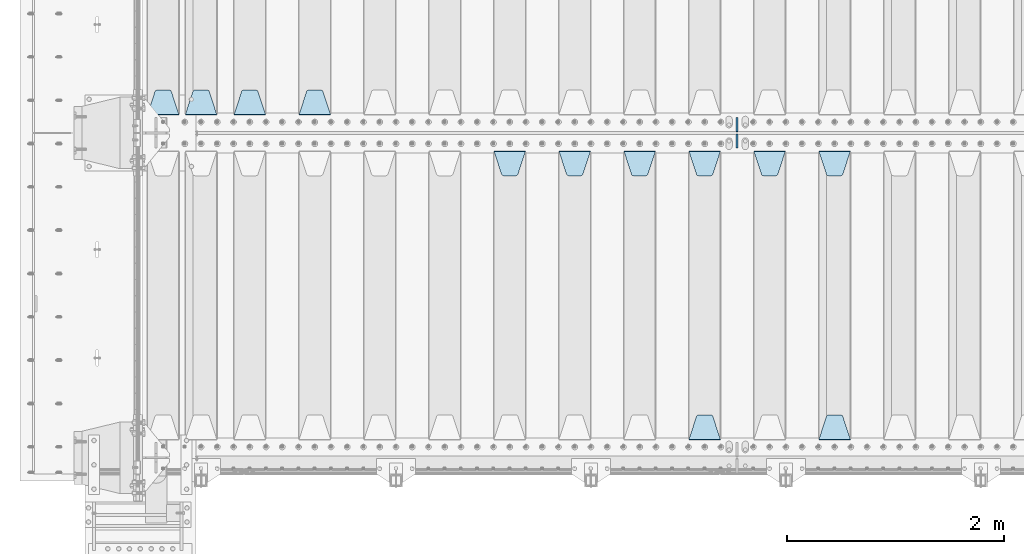
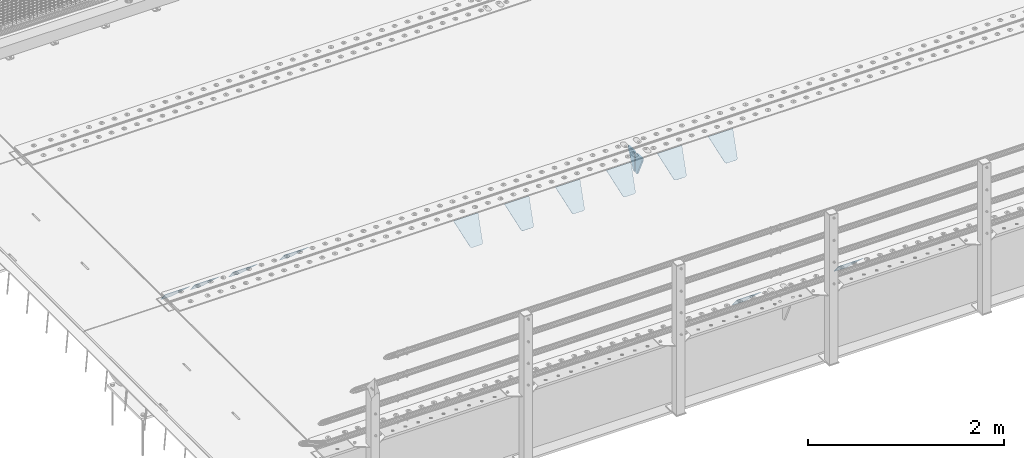
# One storey, part 199 of 247: 14 plates.
"""IFC2X3 building model written with IfcOpenShell, lengths in millimetres."""

from ifc_helpers import new_model, si_unit, frame, origin_with_axes, place, context, subcontext, project, spatial, faceted_brep, material, type_object, element, save


model = new_model("IFC2X3")

# Units and contexts
model_context = context("Model", 3, precision=1e-05, world=origin_with_axes())
body_context = subcontext(model_context, "Body", "Model", "MODEL_VIEW")
ifc_project = project(units=[si_unit("LENGTHUNIT", "METRE", prefix="MILLI"), si_unit("AREAUNIT", "SQUARE_METRE"), si_unit("VOLUMEUNIT", "CUBIC_METRE"), si_unit("MASSUNIT", "GRAM", prefix="KILO"), si_unit("TIMEUNIT", "SECOND"), si_unit("PLANEANGLEUNIT", "RADIAN"), si_unit("SOLIDANGLEUNIT", "STERADIAN"), si_unit("THERMODYNAMICTEMPERATUREUNIT", "DEGREE_CELSIUS"), si_unit("LUMINOUSINTENSITYUNIT", "LUMEN")], contexts=[model_context])

# Site, building, storey
site_placement = place(None, origin_with_axes())
site = spatial("IfcSite", under=ifc_project, at=site_placement, CompositionType="ELEMENT")
building_placement = place(site_placement, origin_with_axes())
building = spatial("IfcBuilding", under=site, at=building_placement, Name="Standard", CompositionType="ELEMENT")
storey_placement = place(building_placement, origin_with_axes())
storey = spatial("IfcBuildingStorey", under=building, at=storey_placement, Name="Undefined", CompositionType="ELEMENT", Elevation=0.0)

# Plates
ifc_material = material(Name="STEEL/S355N")
plate_type_1 = type_object("IfcPlateType", PredefinedType="NOTDEFINED")
plate_1_placement = place(storey_placement, frame((6255.0, 2831.76776695594, -1.767766952965), z_axis=(0.0, -0.707106781186548, -0.707106781186547), x_axis=(1.0, 0.0, 0.0)))
element("IfcPlate", 1, at=plate_1_placement, inside=storey, type_object=plate_type_1, material=ifc_material, context=body_context, shape_type="Brep", body=[
    faceted_brep([(0.0, -2.49999999999909, 0.0), (69.345504679477, -2.5, 300.17173142483), (69.345504679477, 2.50000000000091, 300.171731424831), (0.0, 2.5, -9.09494701772928e-13), (70.9274061199576, -2.5, 304.897442415399), (70.9274061199576, 2.50000000000091, 304.8974424154), (73.3818627772307, -2.49999999999909, 309.234538108527), (73.3818627772307, 2.5, 309.234538108526), (76.6187032999551, -2.5, 313.023683126102), (76.6187032999551, 2.50000000000091, 313.023683126102), (80.5190132704993, -2.49999999999909, 316.125672595371), (80.5190132704993, 2.50000000000091, 316.125672595372), (84.9395038596849, -2.49999999999909, 318.426546230476), (84.9395038596849, 2.5, 318.426546230475), (89.7177759439219, -2.5, 319.841774983274), (89.7177759439219, 2.50000000000091, 319.841774983275), (94.678286292652, -2.5, 320.319366455077), (94.678286292652, 2.50000000000091, 320.319366455077), (195.321713707348, -2.5, 320.319366455077), (195.321713707348, 2.50000000000091, 320.319366455077), (200.282224056078, -2.5, 319.841774983274), (200.282224056078, 2.50000000000091, 319.841774983275), (205.060496140315, -2.5, 318.426546230475), (205.060496140315, 2.5, 318.426546230474), (209.480986729501, -2.49999999999818, 316.12567259537), (209.480986729501, 2.50000000000091, 316.12567259537), (213.381296700045, -2.5, 313.023683126101), (213.381296700045, 2.50000000000091, 313.023683126101), (216.618137222769, -2.5, 309.234538108525), (216.618137222769, 2.5, 309.234538108525), (219.072593880042, -2.49999999999909, 304.897442415398), (219.072593880042, 2.5, 304.897442415398), (220.654495320523, -2.5, 300.17173142483), (220.654495320523, 2.50000000000091, 300.171731424831), (290.0, -2.49999999999909, 0.0), (290.0, 2.5, -9.09494701772928e-13)], [[[0, 1, 2, 3]], [[1, 4, 5, 2]], [[4, 6, 7, 5]], [[6, 8, 9, 7]], [[8, 10, 11, 9]], [[10, 12, 13, 11]], [[12, 14, 15, 13]], [[14, 16, 17, 15]], [[16, 18, 19, 17]], [[18, 20, 21, 19]], [[20, 22, 23, 21]], [[22, 24, 25, 23]], [[24, 26, 27, 25]], [[26, 28, 29, 27]], [[28, 30, 31, 29]], [[30, 32, 33, 31]], [[32, 34, 35, 33]], [[34, 0, 3, 35]], [[5, 7, 9, 11, 13, 15, 17, 19, 21, 23, 25, 27, 29, 31, 33, 35, 3, 2]], [[34, 32, 30, 28, 26, 24, 22, 20, 18, 16, 14, 12, 10, 8, 6, 4, 1, 0]]]),
])
plate_2_placement = place(storey_placement, frame((6545.0, 168.232233047034, -1.76776695296758), z_axis=(0.0, 0.707106781186548, -0.707106781186547), x_axis=(-1.0, 0.0, 0.0)))
element("IfcPlate", 2, at=plate_2_placement, inside=storey, type_object=plate_type_1, material=ifc_material, context=body_context, shape_type="Brep", body=[
    faceted_brep([(0.0, -2.49999999999909, 0.0), (69.345504679477, -2.5, 300.17173142483), (69.345504679477, 2.50000000000091, 300.171731424831), (0.0, 2.5, -9.09494701772928e-13), (70.9274061199576, -2.5, 304.897442415399), (70.9274061199576, 2.50000000000091, 304.8974424154), (73.3818627772307, -2.49999999999909, 309.234538108527), (73.3818627772307, 2.5, 309.234538108526), (76.6187032999551, -2.5, 313.023683126102), (76.6187032999551, 2.50000000000091, 313.023683126102), (80.5190132704993, -2.49999999999909, 316.125672595371), (80.5190132704993, 2.50000000000091, 316.125672595372), (84.9395038596849, -2.49999999999909, 318.426546230476), (84.9395038596849, 2.5, 318.426546230475), (89.7177759439219, -2.5, 319.841774983274), (89.7177759439219, 2.50000000000091, 319.841774983275), (94.678286292652, -2.5, 320.319366455077), (94.678286292652, 2.50000000000091, 320.319366455077), (195.321713707348, -2.5, 320.319366455077), (195.321713707348, 2.50000000000091, 320.319366455077), (200.282224056078, -2.5, 319.841774983274), (200.282224056078, 2.50000000000091, 319.841774983275), (205.060496140315, -2.5, 318.426546230475), (205.060496140315, 2.5, 318.426546230474), (209.480986729501, -2.49999999999818, 316.12567259537), (209.480986729501, 2.50000000000091, 316.12567259537), (213.381296700045, -2.5, 313.023683126101), (213.381296700045, 2.50000000000091, 313.023683126101), (216.618137222769, -2.5, 309.234538108525), (216.618137222769, 2.5, 309.234538108525), (219.072593880042, -2.49999999999909, 304.897442415398), (219.072593880042, 2.5, 304.897442415398), (220.654495320523, -2.5, 300.17173142483), (220.654495320523, 2.50000000000091, 300.171731424831), (290.0, -2.49999999999909, 0.0), (290.0, 2.5, -9.09494701772928e-13)], [[[0, 1, 2, 3]], [[1, 4, 5, 2]], [[4, 6, 7, 5]], [[6, 8, 9, 7]], [[8, 10, 11, 9]], [[10, 12, 13, 11]], [[12, 14, 15, 13]], [[14, 16, 17, 15]], [[16, 18, 19, 17]], [[18, 20, 21, 19]], [[20, 22, 23, 21]], [[22, 24, 25, 23]], [[24, 26, 27, 25]], [[26, 28, 29, 27]], [[28, 30, 31, 29]], [[30, 32, 33, 31]], [[32, 34, 35, 33]], [[34, 0, 3, 35]], [[5, 7, 9, 11, 13, 15, 17, 19, 21, 23, 25, 27, 29, 31, 33, 35, 3, 2]], [[34, 32, 30, 28, 26, 24, 22, 20, 18, 16, 14, 12, 10, 8, 6, 4, 1, 0]]]),
])
plate_3_placement = place(storey_placement, frame((5655.0, 2831.76776695594, -1.767766952965), z_axis=(0.0, -0.707106781186548, -0.707106781186547), x_axis=(1.0, 0.0, 0.0)))
element("IfcPlate", 3, at=plate_3_placement, inside=storey, type_object=plate_type_1, material=ifc_material, context=body_context, shape_type="Brep", body=[
    faceted_brep([(0.0, -2.49999999999909, 0.0), (69.345504679477, -2.5, 300.17173142483), (69.345504679477, 2.50000000000091, 300.171731424831), (0.0, 2.5, -9.09494701772928e-13), (70.9274061199576, -2.5, 304.897442415399), (70.9274061199576, 2.50000000000091, 304.8974424154), (73.3818627772307, -2.49999999999909, 309.234538108527), (73.3818627772307, 2.5, 309.234538108526), (76.6187032999551, -2.5, 313.023683126102), (76.6187032999551, 2.50000000000091, 313.023683126102), (80.5190132704993, -2.49999999999909, 316.125672595371), (80.5190132704993, 2.50000000000091, 316.125672595372), (84.9395038596849, -2.49999999999909, 318.426546230476), (84.9395038596849, 2.5, 318.426546230475), (89.7177759439219, -2.5, 319.841774983274), (89.7177759439219, 2.50000000000091, 319.841774983275), (94.678286292652, -2.5, 320.319366455077), (94.678286292652, 2.50000000000091, 320.319366455077), (195.321713707348, -2.5, 320.319366455077), (195.321713707348, 2.50000000000091, 320.319366455077), (200.282224056078, -2.5, 319.841774983274), (200.282224056078, 2.50000000000091, 319.841774983275), (205.060496140315, -2.5, 318.426546230475), (205.060496140315, 2.5, 318.426546230474), (209.480986729501, -2.49999999999818, 316.12567259537), (209.480986729501, 2.50000000000091, 316.12567259537), (213.381296700045, -2.5, 313.023683126101), (213.381296700045, 2.50000000000091, 313.023683126101), (216.618137222769, -2.5, 309.234538108525), (216.618137222769, 2.5, 309.234538108525), (219.072593880042, -2.49999999999909, 304.897442415398), (219.072593880042, 2.5, 304.897442415398), (220.654495320523, -2.5, 300.17173142483), (220.654495320523, 2.50000000000091, 300.171731424831), (290.0, -2.49999999999909, 0.0), (290.0, 2.5, -9.09494701772928e-13)], [[[0, 1, 2, 3]], [[1, 4, 5, 2]], [[4, 6, 7, 5]], [[6, 8, 9, 7]], [[8, 10, 11, 9]], [[10, 12, 13, 11]], [[12, 14, 15, 13]], [[14, 16, 17, 15]], [[16, 18, 19, 17]], [[18, 20, 21, 19]], [[20, 22, 23, 21]], [[22, 24, 25, 23]], [[24, 26, 27, 25]], [[26, 28, 29, 27]], [[28, 30, 31, 29]], [[30, 32, 33, 31]], [[32, 34, 35, 33]], [[34, 0, 3, 35]], [[5, 7, 9, 11, 13, 15, 17, 19, 21, 23, 25, 27, 29, 31, 33, 35, 3, 2]], [[34, 32, 30, 28, 26, 24, 22, 20, 18, 16, 14, 12, 10, 8, 6, 4, 1, 0]]]),
])
plate_4_placement = place(storey_placement, frame((5055.0, 2831.76776695594, -1.767766952965), z_axis=(0.0, -0.707106781186548, -0.707106781186547), x_axis=(1.0, 0.0, 0.0)))
element("IfcPlate", 4, at=plate_4_placement, inside=storey, type_object=plate_type_1, material=ifc_material, context=body_context, shape_type="Brep", body=[
    faceted_brep([(0.0, -2.49999999999909, 0.0), (69.345504679477, -2.5, 300.17173142483), (69.345504679477, 2.50000000000091, 300.171731424831), (0.0, 2.5, -9.09494701772928e-13), (70.9274061199576, -2.5, 304.897442415399), (70.9274061199576, 2.50000000000091, 304.8974424154), (73.3818627772307, -2.49999999999909, 309.234538108527), (73.3818627772307, 2.5, 309.234538108526), (76.6187032999551, -2.5, 313.023683126102), (76.6187032999551, 2.50000000000091, 313.023683126102), (80.5190132704993, -2.49999999999909, 316.125672595371), (80.5190132704993, 2.50000000000091, 316.125672595372), (84.9395038596849, -2.49999999999909, 318.426546230476), (84.9395038596849, 2.5, 318.426546230475), (89.7177759439219, -2.5, 319.841774983274), (89.7177759439219, 2.50000000000091, 319.841774983275), (94.678286292652, -2.5, 320.319366455077), (94.678286292652, 2.50000000000091, 320.319366455077), (195.321713707348, -2.5, 320.319366455077), (195.321713707348, 2.50000000000091, 320.319366455077), (200.282224056078, -2.5, 319.841774983274), (200.282224056078, 2.50000000000091, 319.841774983275), (205.060496140315, -2.5, 318.426546230475), (205.060496140315, 2.5, 318.426546230474), (209.480986729501, -2.49999999999818, 316.12567259537), (209.480986729501, 2.50000000000091, 316.12567259537), (213.381296700045, -2.5, 313.023683126101), (213.381296700045, 2.50000000000091, 313.023683126101), (216.618137222769, -2.5, 309.234538108525), (216.618137222769, 2.5, 309.234538108525), (219.072593880042, -2.49999999999909, 304.897442415398), (219.072593880042, 2.5, 304.897442415398), (220.654495320523, -2.5, 300.17173142483), (220.654495320523, 2.50000000000091, 300.171731424831), (290.0, -2.49999999999909, 0.0), (290.0, 2.5, -9.09494701772928e-13)], [[[0, 1, 2, 3]], [[1, 4, 5, 2]], [[4, 6, 7, 5]], [[6, 8, 9, 7]], [[8, 10, 11, 9]], [[10, 12, 13, 11]], [[12, 14, 15, 13]], [[14, 16, 17, 15]], [[16, 18, 19, 17]], [[18, 20, 21, 19]], [[20, 22, 23, 21]], [[22, 24, 25, 23]], [[24, 26, 27, 25]], [[26, 28, 29, 27]], [[28, 30, 31, 29]], [[30, 32, 33, 31]], [[32, 34, 35, 33]], [[34, 0, 3, 35]], [[5, 7, 9, 11, 13, 15, 17, 19, 21, 23, 25, 27, 29, 31, 33, 35, 3, 2]], [[34, 32, 30, 28, 26, 24, 22, 20, 18, 16, 14, 12, 10, 8, 6, 4, 1, 0]]]),
])
plate_5_placement = place(storey_placement, frame((5345.0, 168.232233047034, -1.76776695296758), z_axis=(0.0, 0.707106781186548, -0.707106781186547), x_axis=(-1.0, 0.0, 0.0)))
element("IfcPlate", 5, at=plate_5_placement, inside=storey, type_object=plate_type_1, material=ifc_material, context=body_context, shape_type="Brep", body=[
    faceted_brep([(0.0, -2.49999999999909, 0.0), (69.345504679477, -2.5, 300.17173142483), (69.345504679477, 2.50000000000091, 300.171731424831), (0.0, 2.5, -9.09494701772928e-13), (70.9274061199576, -2.5, 304.897442415399), (70.9274061199576, 2.50000000000091, 304.8974424154), (73.3818627772307, -2.49999999999909, 309.234538108527), (73.3818627772307, 2.5, 309.234538108526), (76.6187032999551, -2.5, 313.023683126102), (76.6187032999551, 2.50000000000091, 313.023683126102), (80.5190132704993, -2.49999999999909, 316.125672595371), (80.5190132704993, 2.50000000000091, 316.125672595372), (84.9395038596849, -2.49999999999909, 318.426546230476), (84.9395038596849, 2.5, 318.426546230475), (89.7177759439219, -2.5, 319.841774983274), (89.7177759439219, 2.50000000000091, 319.841774983275), (94.678286292652, -2.5, 320.319366455077), (94.678286292652, 2.50000000000091, 320.319366455077), (195.321713707348, -2.5, 320.319366455077), (195.321713707348, 2.50000000000091, 320.319366455077), (200.282224056078, -2.5, 319.841774983274), (200.282224056078, 2.50000000000091, 319.841774983275), (205.060496140315, -2.5, 318.426546230475), (205.060496140315, 2.5, 318.426546230474), (209.480986729501, -2.49999999999818, 316.12567259537), (209.480986729501, 2.50000000000091, 316.12567259537), (213.381296700045, -2.5, 313.023683126101), (213.381296700045, 2.50000000000091, 313.023683126101), (216.618137222769, -2.5, 309.234538108525), (216.618137222769, 2.5, 309.234538108525), (219.072593880042, -2.49999999999909, 304.897442415398), (219.072593880042, 2.5, 304.897442415398), (220.654495320523, -2.5, 300.17173142483), (220.654495320523, 2.50000000000091, 300.171731424831), (290.0, -2.49999999999909, 0.0), (290.0, 2.5, -9.09494701772928e-13)], [[[0, 1, 2, 3]], [[1, 4, 5, 2]], [[4, 6, 7, 5]], [[6, 8, 9, 7]], [[8, 10, 11, 9]], [[10, 12, 13, 11]], [[12, 14, 15, 13]], [[14, 16, 17, 15]], [[16, 18, 19, 17]], [[18, 20, 21, 19]], [[20, 22, 23, 21]], [[22, 24, 25, 23]], [[24, 26, 27, 25]], [[26, 28, 29, 27]], [[28, 30, 31, 29]], [[30, 32, 33, 31]], [[32, 34, 35, 33]], [[34, 0, 3, 35]], [[5, 7, 9, 11, 13, 15, 17, 19, 21, 23, 25, 27, 29, 31, 33, 35, 3, 2]], [[34, 32, 30, 28, 26, 24, 22, 20, 18, 16, 14, 12, 10, 8, 6, 4, 1, 0]]]),
])
plate_6_placement = place(storey_placement, frame((4455.0, 2831.76776695594, -1.767766952965), z_axis=(0.0, -0.707106781186548, -0.707106781186547), x_axis=(1.0, 0.0, 0.0)))
element("IfcPlate", 6, at=plate_6_placement, inside=storey, type_object=plate_type_1, material=ifc_material, context=body_context, shape_type="Brep", body=[
    faceted_brep([(0.0, -2.49999999999909, 0.0), (69.345504679477, -2.5, 300.17173142483), (69.345504679477, 2.50000000000091, 300.171731424831), (0.0, 2.5, -9.09494701772928e-13), (70.9274061199576, -2.5, 304.897442415399), (70.9274061199576, 2.50000000000091, 304.8974424154), (73.3818627772307, -2.49999999999909, 309.234538108527), (73.3818627772307, 2.5, 309.234538108526), (76.6187032999551, -2.5, 313.023683126102), (76.6187032999551, 2.50000000000091, 313.023683126102), (80.5190132704993, -2.49999999999909, 316.125672595371), (80.5190132704993, 2.50000000000091, 316.125672595372), (84.9395038596849, -2.49999999999909, 318.426546230476), (84.9395038596849, 2.5, 318.426546230475), (89.7177759439219, -2.5, 319.841774983274), (89.7177759439219, 2.50000000000091, 319.841774983275), (94.678286292652, -2.5, 320.319366455077), (94.678286292652, 2.50000000000091, 320.319366455077), (195.321713707348, -2.5, 320.319366455077), (195.321713707348, 2.50000000000091, 320.319366455077), (200.282224056078, -2.5, 319.841774983274), (200.282224056078, 2.50000000000091, 319.841774983275), (205.060496140315, -2.5, 318.426546230475), (205.060496140315, 2.5, 318.426546230474), (209.480986729501, -2.49999999999818, 316.12567259537), (209.480986729501, 2.50000000000091, 316.12567259537), (213.381296700045, -2.5, 313.023683126101), (213.381296700045, 2.50000000000091, 313.023683126101), (216.618137222769, -2.5, 309.234538108525), (216.618137222769, 2.5, 309.234538108525), (219.072593880042, -2.49999999999909, 304.897442415398), (219.072593880042, 2.5, 304.897442415398), (220.654495320523, -2.5, 300.17173142483), (220.654495320523, 2.50000000000091, 300.171731424831), (290.0, -2.49999999999909, 0.0), (290.0, 2.5, -9.09494701772928e-13)], [[[0, 1, 2, 3]], [[1, 4, 5, 2]], [[4, 6, 7, 5]], [[6, 8, 9, 7]], [[8, 10, 11, 9]], [[10, 12, 13, 11]], [[12, 14, 15, 13]], [[14, 16, 17, 15]], [[16, 18, 19, 17]], [[18, 20, 21, 19]], [[20, 22, 23, 21]], [[22, 24, 25, 23]], [[24, 26, 27, 25]], [[26, 28, 29, 27]], [[28, 30, 31, 29]], [[30, 32, 33, 31]], [[32, 34, 35, 33]], [[34, 0, 3, 35]], [[5, 7, 9, 11, 13, 15, 17, 19, 21, 23, 25, 27, 29, 31, 33, 35, 3, 2]], [[34, 32, 30, 28, 26, 24, 22, 20, 18, 16, 14, 12, 10, 8, 6, 4, 1, 0]]]),
])
plate_7_placement = place(storey_placement, frame((3855.0, 2831.76776695594, -1.767766952965), z_axis=(0.0, -0.707106781186548, -0.707106781186547), x_axis=(1.0, 0.0, 0.0)))
element("IfcPlate", 7, at=plate_7_placement, inside=storey, type_object=plate_type_1, material=ifc_material, context=body_context, shape_type="Brep", body=[
    faceted_brep([(0.0, -2.49999999999909, 0.0), (69.345504679477, -2.5, 300.17173142483), (69.345504679477, 2.50000000000091, 300.171731424831), (0.0, 2.5, -9.09494701772928e-13), (70.9274061199576, -2.5, 304.897442415399), (70.9274061199576, 2.50000000000091, 304.8974424154), (73.3818627772307, -2.49999999999909, 309.234538108527), (73.3818627772307, 2.5, 309.234538108526), (76.6187032999551, -2.5, 313.023683126102), (76.6187032999551, 2.50000000000091, 313.023683126102), (80.5190132704993, -2.49999999999909, 316.125672595371), (80.5190132704993, 2.50000000000091, 316.125672595372), (84.9395038596849, -2.49999999999909, 318.426546230476), (84.9395038596849, 2.5, 318.426546230475), (89.7177759439219, -2.5, 319.841774983274), (89.7177759439219, 2.50000000000091, 319.841774983275), (94.678286292652, -2.5, 320.319366455077), (94.678286292652, 2.50000000000091, 320.319366455077), (195.321713707348, -2.5, 320.319366455077), (195.321713707348, 2.50000000000091, 320.319366455077), (200.282224056078, -2.5, 319.841774983274), (200.282224056078, 2.50000000000091, 319.841774983275), (205.060496140315, -2.5, 318.426546230475), (205.060496140315, 2.5, 318.426546230474), (209.480986729501, -2.49999999999818, 316.12567259537), (209.480986729501, 2.50000000000091, 316.12567259537), (213.381296700045, -2.5, 313.023683126101), (213.381296700045, 2.50000000000091, 313.023683126101), (216.618137222769, -2.5, 309.234538108525), (216.618137222769, 2.5, 309.234538108525), (219.072593880042, -2.49999999999909, 304.897442415398), (219.072593880042, 2.5, 304.897442415398), (220.654495320523, -2.5, 300.17173142483), (220.654495320523, 2.50000000000091, 300.171731424831), (290.0, -2.49999999999909, 0.0), (290.0, 2.5, -9.09494701772928e-13)], [[[0, 1, 2, 3]], [[1, 4, 5, 2]], [[4, 6, 7, 5]], [[6, 8, 9, 7]], [[8, 10, 11, 9]], [[10, 12, 13, 11]], [[12, 14, 15, 13]], [[14, 16, 17, 15]], [[16, 18, 19, 17]], [[18, 20, 21, 19]], [[20, 22, 23, 21]], [[22, 24, 25, 23]], [[24, 26, 27, 25]], [[26, 28, 29, 27]], [[28, 30, 31, 29]], [[30, 32, 33, 31]], [[32, 34, 35, 33]], [[34, 0, 3, 35]], [[5, 7, 9, 11, 13, 15, 17, 19, 21, 23, 25, 27, 29, 31, 33, 35, 3, 2]], [[34, 32, 30, 28, 26, 24, 22, 20, 18, 16, 14, 12, 10, 8, 6, 4, 1, 0]]]),
])
plate_8_placement = place(storey_placement, frame((3255.0, 2831.76776695594, -1.767766952965), z_axis=(0.0, -0.707106781186548, -0.707106781186547), x_axis=(1.0, 0.0, 0.0)))
element("IfcPlate", 8, at=plate_8_placement, inside=storey, type_object=plate_type_1, material=ifc_material, context=body_context, shape_type="Brep", body=[
    faceted_brep([(0.0, -2.49999999999909, 0.0), (69.345504679477, -2.5, 300.17173142483), (69.345504679477, 2.50000000000091, 300.171731424831), (0.0, 2.5, -9.09494701772928e-13), (70.9274061199576, -2.5, 304.897442415399), (70.9274061199576, 2.50000000000091, 304.8974424154), (73.3818627772307, -2.49999999999909, 309.234538108527), (73.3818627772307, 2.5, 309.234538108526), (76.6187032999551, -2.5, 313.023683126102), (76.6187032999551, 2.50000000000091, 313.023683126102), (80.5190132704993, -2.49999999999909, 316.125672595371), (80.5190132704993, 2.50000000000091, 316.125672595372), (84.9395038596849, -2.49999999999909, 318.426546230476), (84.9395038596849, 2.5, 318.426546230475), (89.7177759439219, -2.5, 319.841774983274), (89.7177759439219, 2.50000000000091, 319.841774983275), (94.678286292652, -2.5, 320.319366455077), (94.678286292652, 2.50000000000091, 320.319366455077), (195.321713707348, -2.5, 320.319366455077), (195.321713707348, 2.50000000000091, 320.319366455077), (200.282224056078, -2.5, 319.841774983274), (200.282224056078, 2.50000000000091, 319.841774983275), (205.060496140315, -2.5, 318.426546230475), (205.060496140315, 2.5, 318.426546230474), (209.480986729501, -2.49999999999818, 316.12567259537), (209.480986729501, 2.50000000000091, 316.12567259537), (213.381296700045, -2.5, 313.023683126101), (213.381296700045, 2.50000000000091, 313.023683126101), (216.618137222769, -2.5, 309.234538108525), (216.618137222769, 2.5, 309.234538108525), (219.072593880042, -2.49999999999909, 304.897442415398), (219.072593880042, 2.5, 304.897442415398), (220.654495320523, -2.5, 300.17173142483), (220.654495320523, 2.50000000000091, 300.171731424831), (290.0, -2.49999999999909, 0.0), (290.0, 2.5, -9.09494701772928e-13)], [[[0, 1, 2, 3]], [[1, 4, 5, 2]], [[4, 6, 7, 5]], [[6, 8, 9, 7]], [[8, 10, 11, 9]], [[10, 12, 13, 11]], [[12, 14, 15, 13]], [[14, 16, 17, 15]], [[16, 18, 19, 17]], [[18, 20, 21, 19]], [[20, 22, 23, 21]], [[22, 24, 25, 23]], [[24, 26, 27, 25]], [[26, 28, 29, 27]], [[28, 30, 31, 29]], [[30, 32, 33, 31]], [[32, 34, 35, 33]], [[34, 0, 3, 35]], [[5, 7, 9, 11, 13, 15, 17, 19, 21, 23, 25, 27, 29, 31, 33, 35, 3, 2]], [[34, 32, 30, 28, 26, 24, 22, 20, 18, 16, 14, 12, 10, 8, 6, 4, 1, 0]]]),
])
plate_9_placement = place(storey_placement, frame((1745.0, 3168.23223304703, -1.76776695296758), z_axis=(0.0, 0.707106781186548, -0.707106781186547), x_axis=(-1.0, 0.0, 0.0)))
element("IfcPlate", 9, at=plate_9_placement, inside=storey, type_object=plate_type_1, material=ifc_material, context=body_context, shape_type="Brep", body=[
    faceted_brep([(0.0, -2.49999999999909, 0.0), (69.345504679477, -2.5, 300.17173142483), (69.345504679477, 2.50000000000091, 300.171731424831), (0.0, 2.5, -9.09494701772928e-13), (70.9274061199576, -2.5, 304.897442415399), (70.9274061199576, 2.50000000000091, 304.8974424154), (73.3818627772307, -2.49999999999909, 309.234538108527), (73.3818627772307, 2.5, 309.234538108526), (76.6187032999551, -2.5, 313.023683126102), (76.6187032999551, 2.50000000000091, 313.023683126102), (80.5190132704993, -2.49999999999909, 316.125672595371), (80.5190132704993, 2.50000000000091, 316.125672595372), (84.9395038596849, -2.49999999999909, 318.426546230476), (84.9395038596849, 2.5, 318.426546230475), (89.7177759439219, -2.5, 319.841774983274), (89.7177759439219, 2.50000000000091, 319.841774983275), (94.678286292652, -2.5, 320.319366455077), (94.678286292652, 2.50000000000091, 320.319366455077), (195.321713707348, -2.5, 320.319366455077), (195.321713707348, 2.50000000000091, 320.319366455077), (200.282224056078, -2.5, 319.841774983274), (200.282224056078, 2.50000000000091, 319.841774983275), (205.060496140315, -2.5, 318.426546230475), (205.060496140315, 2.5, 318.426546230474), (209.480986729501, -2.49999999999818, 316.12567259537), (209.480986729501, 2.50000000000091, 316.12567259537), (213.381296700045, -2.5, 313.023683126101), (213.381296700045, 2.50000000000091, 313.023683126101), (216.618137222769, -2.5, 309.234538108525), (216.618137222769, 2.5, 309.234538108525), (219.072593880042, -2.49999999999909, 304.897442415398), (219.072593880042, 2.5, 304.897442415398), (220.654495320523, -2.5, 300.17173142483), (220.654495320523, 2.50000000000091, 300.171731424831), (290.0, -2.49999999999909, 0.0), (290.0, 2.5, -9.09494701772928e-13)], [[[0, 1, 2, 3]], [[1, 4, 5, 2]], [[4, 6, 7, 5]], [[6, 8, 9, 7]], [[8, 10, 11, 9]], [[10, 12, 13, 11]], [[12, 14, 15, 13]], [[14, 16, 17, 15]], [[16, 18, 19, 17]], [[18, 20, 21, 19]], [[20, 22, 23, 21]], [[22, 24, 25, 23]], [[24, 26, 27, 25]], [[26, 28, 29, 27]], [[28, 30, 31, 29]], [[30, 32, 33, 31]], [[32, 34, 35, 33]], [[34, 0, 3, 35]], [[5, 7, 9, 11, 13, 15, 17, 19, 21, 23, 25, 27, 29, 31, 33, 35, 3, 2]], [[34, 32, 30, 28, 26, 24, 22, 20, 18, 16, 14, 12, 10, 8, 6, 4, 1, 0]]]),
])
plate_10_placement = place(storey_placement, frame((1145.0, 3168.23223304703, -1.76776695296758), z_axis=(0.0, 0.707106781186548, -0.707106781186547), x_axis=(-1.0, 0.0, 0.0)))
element("IfcPlate", 10, at=plate_10_placement, inside=storey, type_object=plate_type_1, material=ifc_material, context=body_context, shape_type="Brep", body=[
    faceted_brep([(0.0, -2.49999999999909, 0.0), (69.345504679477, -2.5, 300.17173142483), (69.345504679477, 2.50000000000091, 300.171731424831), (0.0, 2.5, -9.09494701772928e-13), (70.9274061199576, -2.5, 304.897442415399), (70.9274061199576, 2.50000000000091, 304.8974424154), (73.3818627772307, -2.49999999999909, 309.234538108527), (73.3818627772307, 2.5, 309.234538108526), (76.6187032999551, -2.5, 313.023683126102), (76.6187032999551, 2.50000000000091, 313.023683126102), (80.5190132704993, -2.49999999999909, 316.125672595371), (80.5190132704993, 2.50000000000091, 316.125672595372), (84.9395038596849, -2.49999999999909, 318.426546230476), (84.9395038596849, 2.5, 318.426546230475), (89.7177759439219, -2.5, 319.841774983274), (89.7177759439219, 2.50000000000091, 319.841774983275), (94.678286292652, -2.5, 320.319366455077), (94.678286292652, 2.50000000000091, 320.319366455077), (195.321713707348, -2.5, 320.319366455077), (195.321713707348, 2.50000000000091, 320.319366455077), (200.282224056078, -2.5, 319.841774983274), (200.282224056078, 2.50000000000091, 319.841774983275), (205.060496140315, -2.5, 318.426546230475), (205.060496140315, 2.5, 318.426546230474), (209.480986729501, -2.49999999999818, 316.12567259537), (209.480986729501, 2.50000000000091, 316.12567259537), (213.381296700045, -2.5, 313.023683126101), (213.381296700045, 2.50000000000091, 313.023683126101), (216.618137222769, -2.5, 309.234538108525), (216.618137222769, 2.5, 309.234538108525), (219.072593880042, -2.49999999999909, 304.897442415398), (219.072593880042, 2.5, 304.897442415398), (220.654495320523, -2.5, 300.17173142483), (220.654495320523, 2.50000000000091, 300.171731424831), (290.0, -2.49999999999909, 0.0), (290.0, 2.5, -9.09494701772928e-13)], [[[0, 1, 2, 3]], [[1, 4, 5, 2]], [[4, 6, 7, 5]], [[6, 8, 9, 7]], [[8, 10, 11, 9]], [[10, 12, 13, 11]], [[12, 14, 15, 13]], [[14, 16, 17, 15]], [[16, 18, 19, 17]], [[18, 20, 21, 19]], [[20, 22, 23, 21]], [[22, 24, 25, 23]], [[24, 26, 27, 25]], [[26, 28, 29, 27]], [[28, 30, 31, 29]], [[30, 32, 33, 31]], [[32, 34, 35, 33]], [[34, 0, 3, 35]], [[5, 7, 9, 11, 13, 15, 17, 19, 21, 23, 25, 27, 29, 31, 33, 35, 3, 2]], [[34, 32, 30, 28, 26, 24, 22, 20, 18, 16, 14, 12, 10, 8, 6, 4, 1, 0]]]),
])
plate_11_placement = place(storey_placement, frame((695.0, 3168.23223304703, -1.76776695296758), z_axis=(0.0, 0.707106781186548, -0.707106781186547), x_axis=(-1.0, 0.0, 0.0)))
element("IfcPlate", 11, at=plate_11_placement, inside=storey, type_object=plate_type_1, material=ifc_material, context=body_context, shape_type="Brep", body=[
    faceted_brep([(0.0, -2.49999999999909, 0.0), (69.345504679477, -2.5, 300.17173142483), (69.345504679477, 2.50000000000091, 300.171731424831), (0.0, 2.5, -9.09494701772928e-13), (70.9274061199576, -2.5, 304.897442415399), (70.9274061199576, 2.50000000000091, 304.8974424154), (73.3818627772307, -2.49999999999909, 309.234538108527), (73.3818627772307, 2.5, 309.234538108526), (76.6187032999551, -2.5, 313.023683126102), (76.6187032999551, 2.50000000000091, 313.023683126102), (80.5190132704993, -2.49999999999909, 316.125672595371), (80.5190132704993, 2.50000000000091, 316.125672595372), (84.9395038596849, -2.49999999999909, 318.426546230476), (84.9395038596849, 2.5, 318.426546230475), (89.7177759439219, -2.5, 319.841774983274), (89.7177759439219, 2.50000000000091, 319.841774983275), (94.678286292652, -2.5, 320.319366455077), (94.678286292652, 2.50000000000091, 320.319366455077), (195.321713707348, -2.5, 320.319366455077), (195.321713707348, 2.50000000000091, 320.319366455077), (200.282224056078, -2.5, 319.841774983274), (200.282224056078, 2.50000000000091, 319.841774983275), (205.060496140315, -2.5, 318.426546230475), (205.060496140315, 2.5, 318.426546230474), (209.480986729501, -2.49999999999818, 316.12567259537), (209.480986729501, 2.50000000000091, 316.12567259537), (213.381296700045, -2.5, 313.023683126101), (213.381296700045, 2.50000000000091, 313.023683126101), (216.618137222769, -2.5, 309.234538108525), (216.618137222769, 2.5, 309.234538108525), (219.072593880042, -2.49999999999909, 304.897442415398), (219.072593880042, 2.5, 304.897442415398), (220.654495320523, -2.5, 300.17173142483), (220.654495320523, 2.50000000000091, 300.171731424831), (290.0, -2.49999999999909, 0.0), (290.0, 2.5, -9.09494701772928e-13)], [[[0, 1, 2, 3]], [[1, 4, 5, 2]], [[4, 6, 7, 5]], [[6, 8, 9, 7]], [[8, 10, 11, 9]], [[10, 12, 13, 11]], [[12, 14, 15, 13]], [[14, 16, 17, 15]], [[16, 18, 19, 17]], [[18, 20, 21, 19]], [[20, 22, 23, 21]], [[22, 24, 25, 23]], [[24, 26, 27, 25]], [[26, 28, 29, 27]], [[28, 30, 31, 29]], [[30, 32, 33, 31]], [[32, 34, 35, 33]], [[34, 0, 3, 35]], [[5, 7, 9, 11, 13, 15, 17, 19, 21, 23, 25, 27, 29, 31, 33, 35, 3, 2]], [[34, 32, 30, 28, 26, 24, 22, 20, 18, 16, 14, 12, 10, 8, 6, 4, 1, 0]]]),
])
plate_12_placement = place(storey_placement, frame((345.0, 3168.23223304703, -1.76776695296758), z_axis=(0.0, 0.707106781186548, -0.707106781186547), x_axis=(-1.0, 0.0, 0.0)))
element("IfcPlate", 12, at=plate_12_placement, inside=storey, type_object=plate_type_1, material=ifc_material, context=body_context, shape_type="Brep", body=[
    faceted_brep([(0.0, -2.49999999999909, 0.0), (69.345504679477, -2.5, 300.17173142483), (69.345504679477, 2.50000000000091, 300.171731424831), (0.0, 2.5, -9.09494701772928e-13), (70.9274061199576, -2.5, 304.897442415399), (70.9274061199576, 2.50000000000091, 304.8974424154), (73.3818627772307, -2.49999999999909, 309.234538108527), (73.3818627772307, 2.5, 309.234538108526), (76.6187032999551, -2.5, 313.023683126102), (76.6187032999551, 2.50000000000091, 313.023683126102), (80.5190132704993, -2.49999999999909, 316.125672595371), (80.5190132704993, 2.50000000000091, 316.125672595372), (84.9395038596849, -2.49999999999909, 318.426546230476), (84.9395038596849, 2.5, 318.426546230475), (89.7177759439219, -2.5, 319.841774983274), (89.7177759439219, 2.50000000000091, 319.841774983275), (94.678286292652, -2.5, 320.319366455077), (94.678286292652, 2.50000000000091, 320.319366455077), (195.321713707348, -2.5, 320.319366455077), (195.321713707348, 2.50000000000091, 320.319366455077), (200.282224056078, -2.5, 319.841774983274), (200.282224056078, 2.50000000000091, 319.841774983275), (205.060496140315, -2.5, 318.426546230475), (205.060496140315, 2.5, 318.426546230474), (209.480986729501, -2.49999999999818, 316.12567259537), (209.480986729501, 2.50000000000091, 316.12567259537), (213.381296700045, -2.5, 313.023683126101), (213.381296700045, 2.50000000000091, 313.023683126101), (216.618137222769, -2.5, 309.234538108525), (216.618137222769, 2.5, 309.234538108525), (219.072593880042, -2.49999999999909, 304.897442415398), (219.072593880042, 2.5, 304.897442415398), (220.654495320523, -2.5, 300.17173142483), (220.654495320523, 2.50000000000091, 300.171731424831), (290.0, -2.49999999999909, 0.0), (290.0, 2.5, -9.09494701772928e-13)], [[[0, 1, 2, 3]], [[1, 4, 5, 2]], [[4, 6, 7, 5]], [[6, 8, 9, 7]], [[8, 10, 11, 9]], [[10, 12, 13, 11]], [[12, 14, 15, 13]], [[14, 16, 17, 15]], [[16, 18, 19, 17]], [[18, 20, 21, 19]], [[20, 22, 23, 21]], [[22, 24, 25, 23]], [[24, 26, 27, 25]], [[26, 28, 29, 27]], [[28, 30, 31, 29]], [[30, 32, 33, 31]], [[32, 34, 35, 33]], [[34, 0, 3, 35]], [[5, 7, 9, 11, 13, 15, 17, 19, 21, 23, 25, 27, 29, 31, 33, 35, 3, 2]], [[34, 32, 30, 28, 26, 24, 22, 20, 18, 16, 14, 12, 10, 8, 6, 4, 1, 0]]]),
])
plate_type_2 = type_object("IfcPlateType", PredefinedType="NOTDEFINED")
for number, where, z_axis, x_axis in (
    (13, (5500.0, 3140.0, -30.0), (0.0, 0.0, -1.0), (0.0, -0.999999999999548, -9.5100000000016e-07)),
    (14, (5500.0, 2860.0, -30.0), (0.0, 0.0, -1.0), (0.0, 1.0, 0.0)),
):
    element("IfcPlate", number, at=place(storey_placement, frame(where, z_axis=z_axis, x_axis=x_axis)), inside=storey, type_object=plate_type_2, material=ifc_material, context=body_context, shape_type="Brep", body=[
        faceted_brep([(-5.6843418860808e-14, -9.99999999999989, 3.5527136788005e-15), (0.0, -10.0, 30.0), (0.0, 10.0, 30.0), (-5.6843418860808e-14, 10.0000000000001, 3.5527136788005e-15), (102.0, -10.0, 250.0), (102.0, 10.0, 250.0), (132.0, -10.0, 250.0), (132.0, 10.0, 250.0), (132.0, -10.0, 30.0), (132.0, 10.0, 30.0), (131.544232590366, -10.0, 24.790554669992), (131.544232590366, 10.0, 24.790554669992), (130.190778623577, -10.0, 19.7393957002299), (130.190778623577, 10.0, 19.7393957002299), (127.980762113533, -10.0, 15.0), (127.980762113533, 10.0, 15.0), (124.981333293569, -10.0, 10.7163717094038), (124.981333293569, 10.0, 10.7163717094038), (121.283628290596, -10.0, 7.01866670643062), (121.283628290596, 10.0, 7.01866670643062), (117.0, -10.0, 4.01923788646684), (117.0, 10.0, 4.01923788646684), (112.26060429977, -10.0, 1.80922137642278), (112.26060429977, 10.0, 1.80922137642278), (107.209445330008, -10.0, 0.455767409633722), (107.209445330008, 10.0, 0.455767409633722), (102.0, -10.0, 0.0), (102.0, 10.0, 0.0)], [[[0, 1, 2, 3]], [[1, 4, 5, 2]], [[4, 6, 7, 5]], [[6, 8, 9, 7]], [[8, 10, 11, 9]], [[10, 12, 13, 11]], [[12, 14, 15, 13]], [[14, 16, 17, 15]], [[16, 18, 19, 17]], [[18, 20, 21, 19]], [[20, 22, 23, 21]], [[22, 24, 25, 23]], [[24, 26, 27, 25]], [[26, 0, 3, 27]], [[5, 7, 9, 11, 13, 15, 17, 19, 21, 23, 25, 27, 3, 2]], [[26, 24, 22, 20, 18, 16, 14, 12, 10, 8, 6, 4, 1, 0]]]),
    ])

save(model, "model.ifc")
